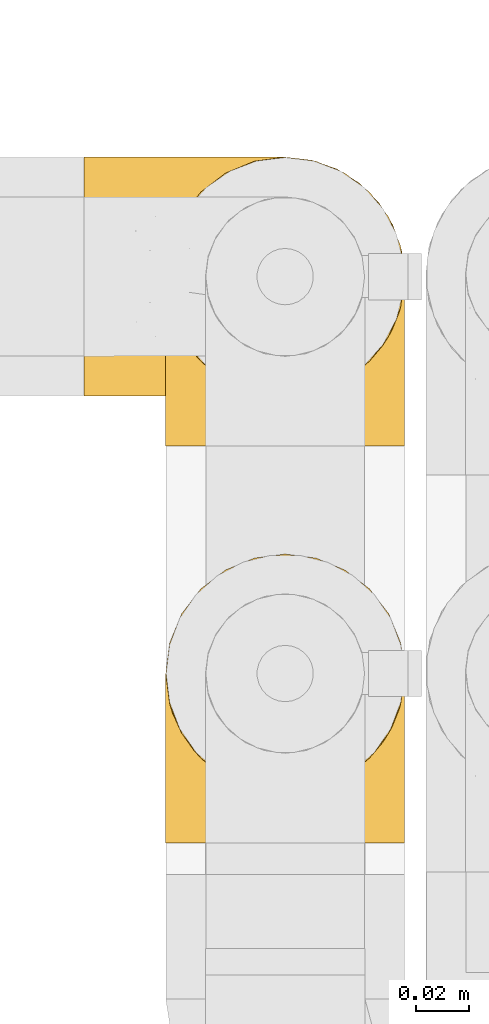
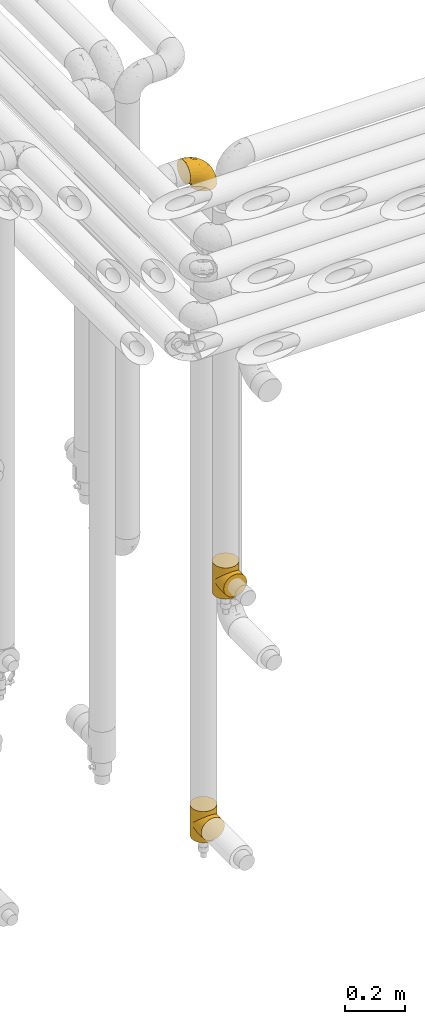
# One storey, part 245 of 827: 3 coverings.
"""IFC2X3 building model written with IfcOpenShell, lengths in millimetres."""

import ifcopenshell
import ifcopenshell.guid

model = None  # the IFC model being written
_history = None  # IfcOwnerHistory: only IFC2X3 demands one
_inside = {}  # id of a spatial element -> (the spatial element, [elements in it])
_under = {}  # id of a project, library or spatial element -> (it, [spatial elements below it])
_declared = {}  # id of a project -> (the project, [libraries it declares])
_typed = {}  # id of a type object -> (the type object, [elements of that type])
_made_of = {}  # id of a material, layer set ... -> (it, [elements and type objects made of it])


def new_model(schema):
    """Start an empty IFC model of exactly this schema.

    Asked for "IFC4X3", IfcOpenShell would pick the latest addendum, in which some entities
    have other attributes; the version numbers below select the first issue.
    IFC2X3 requires an IfcOwnerHistory on every rooted entity: one is made here for all.
    """
    global model, _history
    if schema == "IFC4X3":
        model = ifcopenshell.file(schema_version=(4, 3, 0, 0))
    else:
        model = ifcopenshell.file(schema=schema)
    _inside.clear()
    _under.clear()
    _declared.clear()
    _typed.clear()
    _made_of.clear()
    _history = None
    if model.schema == "IFC2X3":
        org = make("IfcOrganization", Name="unknown")
        user = make(
            "IfcPersonAndOrganization",
            ThePerson=make("IfcPerson", FamilyName="unknown"),
            TheOrganization=org,
        )
        app = make(
            "IfcApplication",
            ApplicationDeveloper=org,
            Version="unknown",
            ApplicationFullName="unknown",
            ApplicationIdentifier="unknown",
        )
        _history = make(
            "IfcOwnerHistory",
            OwningUser=user,
            OwningApplication=app,
            ChangeAction="ADDED",
            CreationDate=0,
        )
    return model


def make(cls, **values):
    """One entity of the class cls with the attributes given. An attribute that is None is left unset."""
    return model.create_entity(
        cls, **{name: value for name, value in values.items() if value is not None}
    )


def entity(cls, *values):
    """Any entity or typed value of the class cls, its attributes in the order of the schema. None: left unset."""
    e = model.create_entity(cls)
    for i, value in enumerate(values):
        if value is not None:
            e[i] = value
    return e


def rooted(cls, **values):
    """An entity with a GlobalId (a new one), such as an element, a storey or a relation."""
    return make(cls, GlobalId=ifcopenshell.guid.new(), OwnerHistory=_history, **values)


def si_unit(unit_type, name, prefix=None):
    """IfcSIUnit, for example si_unit("LENGTHUNIT", "METRE", prefix="MILLI")."""
    return make("IfcSIUnit", UnitType=unit_type, Prefix=prefix, Name=name)


def converted_unit(unit_type, name, factor, base, dimensions=None, offset=None):
    """IfcConversionBasedUnit, such as the inch: factor (a typed value) times the base unit."""
    return make(
        "IfcConversionBasedUnit"
        if offset is None
        else "IfcConversionBasedUnitWithOffset",
        ConversionOffset=offset,
        Dimensions=None
        if dimensions is None
        else entity("IfcDimensionalExponents", *dimensions),
        UnitType=unit_type,
        Name=name,
        ConversionFactor=make(
            "IfcMeasureWithUnit", ValueComponent=factor, UnitComponent=base
        ),
    )


def derived_unit(unit_type, elements):
    """IfcDerivedUnit: a product of units, each with its exponent."""
    return make(
        "IfcDerivedUnit",
        Elements=[
            make("IfcDerivedUnitElement", Unit=unit, Exponent=power)
            for unit, power in elements
        ],
        UnitType=unit_type,
    )


def assignment(units):
    """IfcUnitAssignment: the units of a project."""
    return None if units is None else make("IfcUnitAssignment", Units=units)


def point(xyz):
    """IfcCartesianPoint."""
    return None if xyz is None else make("IfcCartesianPoint", Coordinates=xyz)


def direction(xyz):
    """IfcDirection."""
    return None if xyz is None else make("IfcDirection", DirectionRatios=xyz)


def frame(location, z_axis=None, x_axis=None):
    """IfcAxis2Placement3D, a coordinate frame: its origin and axes. An axis left out is left unset."""
    return make(
        "IfcAxis2Placement3D",
        Location=point(location),
        Axis=direction(z_axis),
        RefDirection=direction(x_axis),
    )


def origin():
    """The frame at (0, 0, 0) with its axes left unset."""
    return frame((0.0, 0.0, 0.0))


def place(relative_to, where):
    """IfcLocalPlacement: puts the frame where relative to a parent placement (None: the world)."""
    return make(
        "IfcLocalPlacement", PlacementRelTo=relative_to, RelativePlacement=where
    )


def context(
    kind, dimensions, precision=None, world=None, true_north=None, identifier=None
):
    """IfcGeometricRepresentationContext, for example the 3D "Model" context."""
    return make(
        "IfcGeometricRepresentationContext",
        ContextIdentifier=identifier,
        ContextType=kind,
        CoordinateSpaceDimension=dimensions,
        Precision=precision,
        WorldCoordinateSystem=world,
        TrueNorth=true_north,
    )


def subcontext(parent, identifier, kind, view, scale=None):
    """IfcGeometricRepresentationSubContext, for example "Body" below "Model"."""
    return make(
        "IfcGeometricRepresentationSubContext",
        ContextIdentifier=identifier,
        ContextType=kind,
        ParentContext=parent,
        TargetScale=scale,
        TargetView=view,
    )


def project(units=None, contexts=None):
    """IfcProject with its units and contexts."""
    return rooted(
        "IfcProject",
        Name="project",
        RepresentationContexts=contexts,
        UnitsInContext=assignment(units),
    )


def spatial(cls, under=None, at=None, **own):
    """A site, building, storey or space (cls), placed at a placement, below another one or the project."""
    s = rooted(cls, ObjectPlacement=at, **own)
    if under is not None:
        _under.setdefault(under.id(), (under, []))[1].append(s)
    return s


def faces_of(points, faces, orient=None, outer=None):
    """IfcFace entities. A face is a list of loops; a loop is a list of indices into points, from 0.

    orient and outer hold one flag for each loop. By default every Orientation is true, the
    first loop of a face is its IfcFaceOuterBound and the others are IfcFaceBound.
    """
    made = []
    for i, loops in enumerate(faces):
        bounds = []
        for j, loop in enumerate(loops):
            is_outer = j == 0 if outer is None else outer[i][j]
            bounds.append(
                make(
                    "IfcFaceOuterBound" if is_outer else "IfcFaceBound",
                    Bound=make("IfcPolyLoop", Polygon=[points[k] for k in loop]),
                    Orientation=True if orient is None else orient[i][j],
                )
            )
        made.append(make("IfcFace", Bounds=bounds))
    return made


def faceted_brep(points, faces, orient=None, outer=None, voids=None):
    """IfcFacetedBrep: a solid bounded by flat faces; with voids (closed shells), ...WithVoids."""
    shared = [point(p) for p in points]
    hull = make("IfcClosedShell", CfsFaces=faces_of(shared, faces, orient, outer))
    if voids is None:
        return make("IfcFacetedBrep", Outer=hull)
    return make(
        "IfcFacetedBrepWithVoids",
        Outer=hull,
        Voids=[
            make(cls, CfsFaces=faces_of(shared, fs, o, b)) for cls, fs, o, b in voids
        ],
    )


def shape(context_of_items, identifier, shape_type, items):
    """IfcShapeRepresentation: the items that make up one representation, for example the "Body"."""
    return make(
        "IfcShapeRepresentation",
        ContextOfItems=context_of_items,
        RepresentationIdentifier=identifier,
        RepresentationType=shape_type,
        Items=items,
    )


def made_of(thing, what):
    """Note that an element or type object is made of a material, layer set ...; save() writes the relation."""
    if what is not None:
        _made_of.setdefault(what.id(), (what, []))[1].append(thing)
    return thing


def element(
    cls,
    number,
    at=None,
    inside=None,
    cuts=None,
    type_object=None,
    material=None,
    context=None,
    identifier="Body",
    shape_type=None,
    held_by="IfcProductDefinitionShape",
    body=None,
    shapes=None,
    **own,
):
    """One element of the class cls, such as IfcWall. Its Tag is "e" and its number.

    at: its placement. inside: the storey or other place that contains it. cuts: it is an
    opening in that element (IfcRelVoidsElement). A single representation is given by context,
    identifier, shape_type and body (its items); several are given by shapes. held_by: the class
    of the entity that holds the representations. save() writes the other relations.
    """
    e = rooted(cls, Tag="e%d" % number, ObjectPlacement=at, **own)
    if body is not None:
        shapes = [shape(context, identifier, shape_type, body)]
    if shapes is not None:
        e.Representation = make(held_by, Representations=shapes)
    if inside is not None:
        _inside.setdefault(inside.id(), (inside, []))[1].append(e)
    if cuts is not None:
        rooted(
            "IfcRelVoidsElement", RelatingBuildingElement=cuts, RelatedOpeningElement=e
        )
    if type_object is not None:
        _typed.setdefault(type_object.id(), (type_object, []))[1].append(e)
    return made_of(e, material)


def aggregate(whole, parts):
    """IfcRelAggregates: a whole, such as a stair, and the parts it consists of."""
    return rooted("IfcRelAggregates", RelatingObject=whole, RelatedObjects=parts)


def save(model, path):
    """Write the relations noted so far, then the file.

    IfcRelAggregates (storeys below a building ...), IfcRelContainedInSpatialStructure (elements
    in a storey), IfcRelDefinesByType, IfcRelAssociatesMaterial and IfcRelDeclares: one each for
    every whole, place, type object, material and project.
    """
    for whole, parts in _under.values():
        aggregate(whole, parts)
    for where, things in _inside.values():
        rooted(
            "IfcRelContainedInSpatialStructure",
            RelatedElements=things,
            RelatingStructure=where,
        )
    for kind, things in _typed.values():
        rooted("IfcRelDefinesByType", RelatedObjects=things, RelatingType=kind)
    for what, things in _made_of.values():
        rooted("IfcRelAssociatesMaterial", RelatedObjects=things, RelatingMaterial=what)
    for by, libraries in _declared.values():
        rooted("IfcRelDeclares", RelatingContext=by, RelatedDefinitions=libraries)
    model.write(path)


model = new_model("IFC2X3")

# Units and contexts
model_context = context("Model", 3, precision=0.01, world=origin(), true_north=direction((6.12303176911189e-17, 1.0)))
body_context = subcontext(model_context, "Body", "Model", "MODEL_VIEW")
ifc_project = project(units=[si_unit("LENGTHUNIT", "METRE", prefix="MILLI"), si_unit("AREAUNIT", "SQUARE_METRE"), si_unit("VOLUMEUNIT", "CUBIC_METRE"), converted_unit("PLANEANGLEUNIT", "DEGREE", entity("IfcRatioMeasure", 0.0174532925199433), si_unit("PLANEANGLEUNIT", "RADIAN"), dimensions=[0, 0, 0, 0, 0, 0, 0]), si_unit("MASSUNIT", "GRAM", prefix="KILO"), derived_unit("MASSDENSITYUNIT", [(si_unit("MASSUNIT", "GRAM", prefix="KILO"), 1), (si_unit("LENGTHUNIT", "METRE"), -3)]), derived_unit("MOMENTOFINERTIAUNIT", [(si_unit("LENGTHUNIT", "METRE"), 4)]), si_unit("TIMEUNIT", "SECOND"), si_unit("FREQUENCYUNIT", "HERTZ"), si_unit("THERMODYNAMICTEMPERATUREUNIT", "DEGREE_CELSIUS"), derived_unit("THERMALTRANSMITTANCEUNIT", [(si_unit("MASSUNIT", "GRAM", prefix="KILO"), 1), (si_unit("THERMODYNAMICTEMPERATUREUNIT", "KELVIN"), -1), (si_unit("TIMEUNIT", "SECOND"), -3)]), derived_unit("VOLUMETRICFLOWRATEUNIT", [(si_unit("LENGTHUNIT", "METRE"), 3), (si_unit("TIMEUNIT", "SECOND"), -1)]), derived_unit("MASSFLOWRATEUNIT", [(si_unit("MASSUNIT", "GRAM", prefix="KILO"), 1), (si_unit("TIMEUNIT", "SECOND"), -1)]), derived_unit("ROTATIONALFREQUENCYUNIT", [(si_unit("TIMEUNIT", "SECOND"), -1)]), si_unit("ELECTRICCURRENTUNIT", "AMPERE"), si_unit("ELECTRICVOLTAGEUNIT", "VOLT"), si_unit("POWERUNIT", "WATT"), si_unit("FORCEUNIT", "NEWTON", prefix="KILO"), si_unit("ILLUMINANCEUNIT", "LUX"), si_unit("LUMINOUSFLUXUNIT", "LUMEN"), si_unit("LUMINOUSINTENSITYUNIT", "CANDELA"), derived_unit("USERDEFINED", [(si_unit("MASSUNIT", "GRAM", prefix="KILO"), -1), (si_unit("LENGTHUNIT", "METRE"), -2), (si_unit("TIMEUNIT", "SECOND"), 3), (si_unit("LUMINOUSFLUXUNIT", "LUMEN"), 1)]), derived_unit("LINEARVELOCITYUNIT", [(si_unit("LENGTHUNIT", "METRE"), 1), (si_unit("TIMEUNIT", "SECOND"), -1)]), si_unit("PRESSUREUNIT", "PASCAL"), derived_unit("USERDEFINED", [(si_unit("LENGTHUNIT", "METRE"), -2), (si_unit("MASSUNIT", "GRAM", prefix="KILO"), 1), (si_unit("TIMEUNIT", "SECOND"), -2)]), derived_unit("LINEARFORCEUNIT", [(si_unit("MASSUNIT", "GRAM", prefix="KILO"), 1), (si_unit("LENGTHUNIT", "METRE"), 1), (si_unit("TIMEUNIT", "SECOND"), -2), (si_unit("LENGTHUNIT", "METRE"), -1)]), derived_unit("PLANARFORCEUNIT", [(si_unit("MASSUNIT", "GRAM", prefix="KILO"), 1), (si_unit("LENGTHUNIT", "METRE"), 1), (si_unit("TIMEUNIT", "SECOND"), -2), (si_unit("LENGTHUNIT", "METRE"), -2)])], contexts=[model_context])

# Site, building, storey
site_placement = place(None, origin())
site = spatial("IfcSite", under=ifc_project, at=site_placement, CompositionType="ELEMENT")
building_placement = place(site_placement, origin())
building = spatial("IfcBuilding", under=site, at=building_placement, CompositionType="ELEMENT")
storey_placement = place(building_placement, frame((0.0, 0.0, 28200.0)))
storey = spatial("IfcBuildingStorey", under=building, at=storey_placement, Name="08", CompositionType="ELEMENT", Elevation=28200.0)

# Coverings
covering_1_placement = place(storey_placement, frame((31569.16, 15092.26, 2922.4)))
element("IfcCovering", 1, at=covering_1_placement, inside=storey, Name=":ADSK_", ObjectType=":ADSK_", PredefinedType="INSULATION", context=body_context, shape_type="Brep", body=[
    faceted_brep([(87.65, 90.76, 1.6), (97.19, 87.42, 1.6), (105.75, 82.04, 1.6), (112.9, 74.89, 1.6), (118.28, 66.33, 1.6), (121.61, 56.79, 1.6), (122.75, 46.75, 1.6), (121.61, 36.69, 1.6), (118.27, 27.15, 1.6), (112.89, 18.59, 1.6), (105.74, 11.44, 1.6), (97.18, 6.06, 1.6), (87.64, 2.73, 1.6), (77.6, 1.6, 1.6), (67.54, 2.73, 1.6), (58.0, 6.07, 1.6), (49.44, 11.45, 1.6), (42.29, 18.6, 1.6), (36.91, 27.16, 1.6), (33.58, 36.7, 1.6), (32.45, 46.75, 1.6), (33.58, 56.8, 1.6), (36.92, 66.34, 1.6), (42.3, 74.9, 1.6), (49.45, 82.05, 1.6), (58.01, 87.43, 1.6), (67.55, 90.76, 1.6), (77.6, 91.9, 1.6), (1.6, 35.06, 33.98), (1.6, 24.17, 38.49), (1.6, 14.82, 45.67), (1.6, 7.64, 55.02), (1.6, 3.13, 65.91), (1.6, 1.6, 77.6), (1.6, 3.13, 89.28), (1.6, 7.64, 100.17), (1.6, 14.82, 109.52), (1.6, 24.17, 116.7), (1.6, 35.06, 121.21), (1.6, 46.75, 122.75), (1.6, 58.43, 121.21), (1.6, 69.32, 116.7), (1.6, 78.67, 109.52), (1.6, 85.85, 100.17), (1.6, 90.36, 89.28), (1.6, 91.9, 77.6), (1.6, 90.36, 65.91), (1.6, 85.85, 55.02), (1.6, 78.67, 45.67), (1.6, 69.32, 38.49), (1.6, 58.43, 33.98), (1.6, 46.75, 32.45), (99.61, 46.75, 72.81), (95.26, 55.2, 77.17), (86.21, 46.75, 86.21), (39.03, 46.75, 116.82), (30.75, 54.53, 118.49), (23.8, 46.75, 119.23), (60.8, 59.63, 105.14), (85.37, 62.07, 85.37), (73.64, 71.86, 89.33), (31.01, 62.65, 116.14), (49.14, 71.33, 105.06), (23.88, 72.93, 112.15), (82.74, 91.2, 22.95), (43.48, 86.31, 89.91), (29.47, 80.89, 103.39), (56.38, 79.49, 93.6), (72.18, 90.68, 51.41), (72.24, 86.84, 67.71), (87.6, 87.38, 43.53), (107.24, 76.87, 30.91), (101.1, 83.73, 23.58), (95.16, 81.03, 50.07), (71.81, 91.9, 30.68), (63.57, 91.9, 43.01), (55.34, 91.9, 55.34), (23.66, 91.03, 83.48), (20.55, 87.58, 94.96), (107.97, 56.52, 57.29), (116.82, 46.75, 39.03), (117.03, 60.4, 30.66), (30.68, 91.9, 71.81), (21.51, 91.9, 73.63), (12.33, 91.9, 75.46), (106.17, 67.87, 51.57), (52.37, 90.35, 73.13), (114.51, 69.57, 23.16), (119.23, 46.75, 23.8), (78.37, 79.91, 75.6), (75.46, 91.9, 12.33), (73.63, 91.9, 21.51), (101.51, 74.99, 50.46), (72.81, 46.75, 99.61), (43.01, 91.9, 63.57), (92.6, 88.53, 21.26), (91.86, 72.65, 69.54), (55.92, 46.75, 108.21), (99.01, 62.97, 68.42), (108.21, 46.75, 55.92), (32.05, 66.2, 19.36), (30.22, 56.6, 15.76), (23.37, 59.89, 26.13), (28.43, 90.95, 62.78), (16.44, 90.22, 63.65), (37.1, 76.64, 24.34), (28.88, 71.58, 28.46), (33.93, 79.99, 33.53), (50.17, 89.54, 39.46), (40.57, 89.97, 51.05), (47.62, 81.32, 10.94), (39.9, 74.56, 14.55), (47.92, 84.15, 22.21), (34.27, 90.37, 57.05), (24.65, 87.82, 54.0), (62.6, 90.98, 29.19), (66.18, 90.96, 18.85), (11.74, 85.14, 52.84), (13.89, 58.11, 31.47), (17.02, 46.75, 28.31), (15.86, 78.39, 43.0), (57.71, 88.22, 16.9), (9.11, 66.06, 35.98), (18.55, 68.6, 33.91), (34.74, 63.78, 9.97), (54.95, 88.42, 25.93), (57.35, 90.61, 35.61), (22.03, 83.8, 47.45), (24.8, 77.98, 38.26), (69.07, 91.22, 11.7), (42.31, 83.46, 30.13), (29.63, 46.75, 12.12), (28.31, 46.75, 17.02), (30.23, 84.66, 44.39), (40.13, 86.33, 39.83), (22.67, 46.75, 22.67), (12.12, 46.75, 29.63), (15.86, 15.1, 43.0), (22.03, 9.69, 47.45), (24.8, 15.52, 38.26), (30.23, 8.83, 44.38), (13.88, 35.39, 31.47), (47.61, 12.18, 10.93), (73.63, 1.6, 21.51), (66.17, 2.53, 18.84), (69.07, 2.27, 11.7), (30.22, 36.9, 15.76), (32.04, 27.31, 19.36), (23.36, 33.62, 26.14), (54.93, 5.07, 25.94), (47.91, 9.36, 22.21), (57.69, 5.27, 16.9), (9.1, 27.43, 35.98), (21.51, 1.6, 73.63), (12.33, 1.6, 75.46), (42.29, 10.05, 30.12), (37.09, 16.87, 24.33), (11.74, 8.35, 52.84), (16.44, 3.27, 63.65), (30.68, 1.6, 71.81), (28.86, 21.94, 28.45), (34.74, 29.72, 9.97), (63.57, 1.6, 43.01), (55.34, 1.6, 55.34), (50.17, 3.96, 39.46), (75.46, 1.6, 12.33), (39.89, 18.95, 14.54), (28.43, 2.54, 62.78), (34.27, 3.12, 57.05), (43.01, 1.6, 63.57), (62.59, 2.51, 29.2), (40.57, 3.52, 51.05), (40.13, 7.17, 39.81), (71.81, 1.6, 30.68), (33.92, 13.52, 33.52), (57.34, 2.88, 35.61), (24.65, 5.67, 54.0), (18.54, 24.89, 33.91), (29.47, 12.6, 103.39), (43.48, 7.18, 89.91), (56.4, 14.0, 93.6), (49.17, 22.16, 105.05), (73.69, 21.61, 89.27), (52.37, 3.14, 73.13), (72.26, 6.65, 67.67), (91.88, 20.82, 69.49), (85.36, 31.41, 85.36), (20.55, 5.91, 94.96), (23.66, 2.46, 83.48), (60.8, 33.87, 105.14), (31.02, 30.84, 116.13), (30.75, 38.96, 118.49), (23.9, 20.56, 112.15), (72.17, 2.81, 51.41), (87.59, 6.1, 43.51), (82.74, 2.29, 22.95), (117.03, 33.08, 30.66), (107.23, 16.61, 30.91), (107.97, 36.96, 57.3), (101.08, 9.75, 23.58), (106.17, 25.61, 51.56), (99.01, 30.5, 68.41), (114.5, 23.91, 23.16), (95.15, 12.45, 50.07), (101.5, 18.49, 50.45), (92.59, 4.96, 21.25), (78.38, 13.56, 75.56), (95.27, 38.28, 77.16)], [[[0, 1, 2, 3, 4, 5, 6, 7, 8, 9, 10, 11, 12, 13, 14, 15, 16, 17, 18, 19, 20, 21, 22, 23, 24, 25, 26, 27]], [[28, 29, 30, 31, 32, 33, 34, 35, 36, 37, 38, 39, 40, 41, 42, 43, 44, 45, 46, 47, 48, 49, 50, 51]], [[52, 53, 54]], [[55, 56, 57]], [[58, 59, 60]], [[61, 62, 63]], [[27, 64, 0]], [[65, 66, 67]], [[41, 40, 61]], [[68, 69, 70]], [[66, 43, 42]], [[63, 42, 41]], [[71, 72, 73]], [[72, 2, 1]], [[68, 74, 75, 76]], [[45, 44, 77]], [[43, 78, 44]], [[79, 80, 81]], [[77, 82, 83, 84, 45]], [[79, 81, 85]], [[71, 2, 72]], [[65, 86, 77]], [[4, 81, 5]], [[66, 65, 78]], [[4, 3, 87]], [[81, 88, 5]], [[63, 66, 42]], [[68, 70, 64]], [[67, 60, 89]], [[71, 3, 2]], [[64, 27, 90, 91, 74]], [[92, 71, 73]], [[40, 57, 56]], [[59, 93, 54]], [[86, 76, 94, 82]], [[1, 0, 95]], [[58, 62, 61]], [[60, 96, 89]], [[85, 81, 87]], [[56, 97, 58]], [[65, 67, 69]], [[87, 81, 4]], [[67, 89, 69]], [[61, 63, 41]], [[95, 72, 1]], [[73, 72, 70]], [[69, 73, 70]], [[73, 89, 96]], [[3, 71, 87]], [[85, 87, 71]], [[58, 61, 56]], [[59, 58, 93]], [[76, 86, 68]], [[69, 89, 73]], [[68, 86, 69]], [[65, 69, 86]], [[68, 64, 74]], [[95, 64, 70]], [[98, 79, 85]], [[79, 52, 99, 80]], [[66, 62, 67]], [[62, 58, 60]], [[62, 60, 67]], [[59, 98, 96]], [[59, 96, 60]], [[96, 85, 92]], [[88, 81, 80]], [[88, 6, 5]], [[66, 63, 62]], [[64, 95, 0]], [[72, 95, 70]], [[77, 44, 78]], [[86, 82, 77]], [[40, 39, 57]], [[96, 98, 85]], [[40, 56, 61]], [[66, 78, 43]], [[77, 78, 65]], [[79, 98, 53]], [[96, 92, 73]], [[85, 71, 92]], [[97, 56, 55]], [[97, 93, 58]], [[53, 98, 59]], [[54, 53, 59]], [[79, 53, 52]], [[100, 101, 102]], [[46, 45, 84, 83]], [[103, 104, 82]], [[82, 104, 83]], [[105, 106, 107]], [[108, 109, 76]], [[110, 111, 112]], [[103, 113, 114]], [[115, 74, 116]], [[48, 47, 117]], [[118, 102, 119]], [[49, 48, 120]], [[74, 91, 116]], [[116, 121, 115]], [[49, 122, 50]], [[123, 106, 102]], [[124, 111, 22]], [[125, 126, 115]], [[23, 22, 111]], [[24, 110, 121]], [[120, 127, 128]], [[90, 26, 129]], [[27, 26, 90]], [[121, 125, 115]], [[24, 121, 25]], [[130, 105, 107]], [[129, 25, 116]], [[21, 20, 131]], [[120, 123, 122]], [[112, 105, 130]], [[50, 118, 51]], [[21, 124, 22]], [[101, 131, 132]], [[117, 120, 48]], [[24, 23, 110]], [[127, 114, 133]], [[75, 108, 76]], [[107, 134, 130]], [[133, 114, 113]], [[129, 116, 91]], [[25, 121, 116]], [[121, 112, 125]], [[75, 74, 115]], [[101, 135, 102]], [[131, 101, 21]], [[101, 100, 124]], [[128, 127, 133]], [[119, 136, 51, 118]], [[104, 47, 46]], [[83, 104, 46]], [[117, 104, 114]], [[101, 124, 21]], [[111, 124, 100]], [[102, 118, 123]], [[133, 134, 107]], [[111, 110, 23]], [[114, 104, 103]], [[94, 76, 109]], [[121, 110, 112]], [[122, 118, 50]], [[134, 109, 108]], [[133, 107, 128]], [[112, 108, 125]], [[126, 125, 108]], [[108, 75, 126]], [[75, 115, 126]], [[109, 134, 133]], [[130, 108, 112]], [[108, 130, 134]], [[105, 112, 111]], [[111, 100, 105]], [[106, 105, 100]], [[102, 106, 100]], [[128, 106, 123]], [[90, 129, 91]], [[25, 129, 26]], [[104, 117, 47]], [[117, 114, 127]], [[82, 94, 103]], [[113, 94, 109]], [[94, 113, 103]], [[133, 113, 109]], [[106, 128, 107]], [[123, 120, 128]], [[120, 122, 49]], [[118, 122, 123]], [[135, 101, 132]], [[135, 119, 102]], [[117, 127, 120]], [[30, 29, 137]], [[138, 139, 140]], [[51, 136, 119, 141]], [[142, 17, 16]], [[143, 144, 145]], [[146, 147, 148]], [[149, 150, 151]], [[152, 29, 28]], [[33, 32, 153, 154]], [[150, 155, 156]], [[157, 31, 30]], [[153, 158, 159]], [[29, 152, 137]], [[148, 141, 119]], [[156, 160, 147]], [[148, 135, 146]], [[137, 138, 157]], [[19, 161, 146]], [[162, 163, 164]], [[14, 13, 165]], [[153, 32, 158]], [[147, 161, 166]], [[18, 17, 166]], [[167, 168, 169]], [[166, 150, 156]], [[151, 150, 142]], [[151, 170, 149]], [[151, 16, 15]], [[171, 140, 172]], [[165, 143, 145]], [[173, 170, 144]], [[142, 166, 17]], [[19, 131, 20]], [[144, 170, 151]], [[18, 161, 19]], [[173, 144, 143]], [[140, 139, 174]], [[171, 164, 163]], [[164, 172, 155]], [[151, 15, 144]], [[145, 15, 14]], [[173, 162, 170]], [[149, 175, 164]], [[19, 146, 131]], [[132, 131, 146]], [[160, 148, 147]], [[159, 158, 167]], [[135, 132, 146]], [[158, 32, 31]], [[157, 158, 31]], [[167, 158, 176]], [[166, 161, 18]], [[146, 161, 147]], [[148, 177, 141]], [[171, 168, 140]], [[171, 163, 169]], [[151, 142, 16]], [[166, 142, 150]], [[152, 141, 177]], [[51, 141, 28]], [[138, 140, 176]], [[172, 140, 174]], [[175, 149, 170]], [[164, 150, 149]], [[170, 162, 175]], [[162, 164, 175]], [[155, 172, 174]], [[171, 172, 164]], [[155, 174, 156]], [[164, 155, 150]], [[160, 156, 174]], [[147, 166, 156]], [[139, 160, 174]], [[148, 160, 177]], [[15, 145, 144]], [[165, 145, 14]], [[137, 157, 30]], [[158, 157, 176]], [[168, 167, 176]], [[169, 159, 167]], [[140, 168, 176]], [[169, 168, 171]], [[137, 177, 139]], [[160, 139, 177]], [[141, 152, 28]], [[137, 152, 177]], [[148, 119, 135]], [[157, 138, 176]], [[139, 138, 137]], [[178, 179, 180]], [[181, 180, 182]], [[179, 183, 184]], [[185, 186, 182]], [[187, 188, 179]], [[188, 33, 154, 153, 159]], [[181, 189, 190]], [[35, 34, 187]], [[191, 38, 190]], [[192, 178, 181]], [[179, 184, 180]], [[192, 190, 37]], [[37, 190, 38]], [[36, 35, 178]], [[54, 93, 186]], [[35, 187, 178]], [[193, 194, 184]], [[195, 173, 143, 165, 13]], [[195, 193, 173]], [[193, 163, 162, 173]], [[13, 12, 195]], [[8, 7, 196]], [[9, 197, 10]], [[198, 80, 99, 52]], [[196, 7, 88]], [[197, 199, 10]], [[182, 189, 181]], [[200, 198, 201]], [[200, 196, 198]], [[9, 8, 202]], [[194, 199, 203]], [[192, 37, 36]], [[80, 196, 88]], [[183, 159, 169, 163]], [[188, 34, 33]], [[202, 200, 197]], [[185, 203, 204]], [[202, 8, 196]], [[10, 199, 11]], [[12, 11, 205]], [[38, 191, 57]], [[189, 97, 191]], [[203, 199, 197]], [[205, 199, 194]], [[204, 203, 197]], [[184, 203, 206]], [[200, 202, 196]], [[197, 9, 202]], [[207, 54, 186]], [[97, 55, 191]], [[194, 203, 184]], [[183, 163, 193]], [[184, 206, 180]], [[183, 193, 184]], [[205, 195, 12]], [[193, 195, 194]], [[80, 198, 196]], [[207, 186, 201]], [[182, 180, 206]], [[181, 178, 180]], [[185, 182, 206]], [[182, 186, 189]], [[203, 185, 206]], [[185, 200, 201]], [[7, 6, 88]], [[178, 192, 36]], [[190, 192, 181]], [[199, 205, 11]], [[195, 205, 194]], [[159, 183, 188]], [[179, 188, 183]], [[57, 191, 55]], [[57, 39, 38]], [[189, 191, 190]], [[188, 187, 34]], [[178, 187, 179]], [[186, 93, 189]], [[197, 200, 204]], [[185, 204, 200]], [[189, 93, 97]], [[207, 198, 52]], [[185, 201, 186]], [[198, 207, 201]], [[54, 207, 52]]]),
])
covering_2_placement = place(storey_placement, frame((31600.01, 15075.0, 251.5)))
element("IfcCovering", 2, at=covering_2_placement, inside=storey, Name=":ADSK_", ObjectType=":ADSK_", PredefinedType="INSULATION", context=body_context, shape_type="Brep", body=[
    faceted_brep([(91.39, 57.25, 70.75), (91.9, 64.0, 128.0), (90.36, 52.31, 128.0), (85.85, 41.43, 128.0), (87.26, 44.06, 83.94), (83.54, 37.83, 90.17), (78.67, 32.07, 128.0), (91.9, 64.0, 64.0), (91.39, 57.25, 57.25), (91.9, 64.0, 0.0), (89.85, 50.57, 77.43), (72.42, 26.86, 101.14), (69.32, 24.9, 128.0), (64.9, 22.66, 105.34), (63.88, 22.64, 128.0), (58.43, 20.39, 128.0), (56.19, 19.85, 108.15), (46.75, 18.85, 128.0), (78.62, 32.02, 95.98), (46.75, 18.85, 109.15), (46.75, 18.85, 0.0), (56.19, 19.85, 19.85), (46.75, 18.85, 18.85), (36.15, 20.11, 107.89), (35.06, 20.39, 128.0), (26.59, 23.6, 104.4), (24.17, 24.9, 128.0), (18.6, 28.7, 99.3), (14.82, 32.07, 128.0), (36.15, 20.11, 20.11), (12.26, 34.86, 93.14), (7.5, 41.68, 86.32), (7.64, 41.42, 128.0), (4.19, 48.92, 79.08), (3.13, 52.31, 128.0), (2.24, 56.41, 71.59), (1.6, 64.0, 128.0), (1.6, 64.0, 64.0), (2.24, 56.41, 56.41), (1.6, 64.0, 0.0), (24.17, 103.1, 0.0), (35.06, 107.61, 0.0), (46.75, 109.15, 0.0), (58.43, 107.61, 0.0), (69.32, 103.1, 0.0), (78.67, 95.93, 0.0), (85.85, 86.58, 0.0), (90.36, 75.69, 0.0), (90.36, 52.31, 0.0), (85.85, 41.43, 0.0), (78.67, 32.07, 0.0), (69.32, 24.9, 0.0), (63.88, 22.64, 0.0), (58.43, 20.39, 0.0), (35.06, 20.39, 0.0), (24.17, 24.9, 0.0), (14.82, 32.07, 0.0), (7.64, 41.43, 0.0), (3.13, 52.31, 0.0), (3.13, 75.69, 0.0), (7.64, 86.58, 0.0), (14.82, 95.93, 0.0), (78.67, 95.93, 128.0), (69.32, 103.1, 128.0), (58.43, 107.61, 128.0), (46.75, 109.15, 128.0), (35.06, 107.61, 128.0), (24.17, 103.1, 128.0), (14.82, 95.93, 128.0), (7.64, 86.58, 128.0), (3.13, 75.69, 128.0), (90.36, 75.69, 128.0), (85.85, 86.58, 128.0), (89.85, 50.57, 50.57), (87.26, 44.06, 44.06), (83.54, 37.83, 37.83), (78.62, 32.02, 32.02), (72.42, 26.86, 26.86), (64.9, 22.66, 22.66), (26.59, 23.6, 23.6), (18.6, 28.7, 28.7), (12.26, 34.86, 34.86), (7.5, 41.68, 41.68), (4.19, 48.92, 48.92), (78.67, 0.0, 95.93), (69.32, 0.0, 103.1), (63.88, 0.0, 105.36), (58.43, 0.0, 107.61), (46.75, 0.0, 109.15), (35.06, 0.0, 107.61), (24.17, 0.0, 103.1), (14.82, 0.0, 95.93), (7.64, 0.0, 86.57), (3.13, 0.0, 75.69), (1.6, 0.0, 64.0), (3.13, 0.0, 52.31), (7.64, 0.0, 41.42), (14.82, 0.0, 32.07), (24.17, 0.0, 24.9), (35.06, 0.0, 20.39), (46.75, 0.0, 18.85), (58.43, 0.0, 20.39), (63.88, 0.0, 22.64), (69.32, 0.0, 24.9), (78.67, 0.0, 32.07), (85.85, 0.0, 41.42), (90.36, 0.0, 52.31), (91.9, 0.0, 64.0), (90.36, 0.0, 75.69), (85.85, 0.0, 86.57)], [[[0, 1, 2]], [[2, 3, 4]], [[5, 3, 6]], [[5, 4, 3]], [[0, 7, 1]], [[7, 8, 9]], [[4, 10, 2]], [[0, 2, 10]], [[11, 6, 12]], [[13, 12, 14, 15]], [[16, 15, 17]], [[11, 18, 6]], [[16, 13, 15]], [[19, 16, 17]], [[20, 21, 22]], [[11, 12, 13]], [[6, 18, 5]], [[23, 17, 24]], [[25, 24, 26]], [[27, 26, 28]], [[23, 19, 17]], [[22, 29, 20]], [[27, 25, 26]], [[23, 24, 25]], [[28, 30, 27]], [[31, 30, 32]], [[32, 30, 28]], [[33, 32, 34]], [[35, 34, 36]], [[33, 31, 32]], [[37, 35, 36]], [[38, 37, 39]], [[33, 34, 35]], [[40, 41, 42, 43, 44, 45, 46, 47, 9, 48, 49, 50, 51, 52, 53, 20, 54, 55, 56, 57, 58, 39, 59, 60, 61]], [[62, 63, 64, 65, 66, 67, 68, 69, 70, 36, 34, 32, 28, 26, 24, 17, 15, 14, 12, 6, 3, 2, 1, 71, 72]], [[63, 62, 45, 44]], [[42, 65, 64, 43]], [[44, 43, 64, 63]], [[46, 72, 71, 47]], [[1, 7, 9, 47, 71]], [[45, 62, 72, 46]], [[73, 74, 48]], [[8, 73, 48]], [[9, 8, 48]], [[49, 75, 50]], [[49, 48, 74]], [[75, 49, 74]], [[76, 77, 50]], [[78, 21, 53]], [[78, 53, 52, 51]], [[77, 78, 51]], [[50, 77, 51]], [[21, 20, 53]], [[76, 50, 75]], [[79, 80, 55]], [[29, 79, 54]], [[20, 29, 54]], [[54, 79, 55]], [[80, 56, 55]], [[80, 81, 56]], [[82, 83, 57]], [[83, 38, 58]], [[81, 57, 56]], [[81, 82, 57]], [[57, 83, 58]], [[38, 39, 58]], [[37, 36, 70, 59, 39]], [[59, 70, 69, 60]], [[69, 68, 61, 60]], [[61, 68, 67, 40]], [[40, 67, 66, 41]], [[41, 66, 65, 42]], [[84, 85, 86, 87, 88, 89, 90, 91, 92, 93, 94, 95, 96, 97, 98, 99, 100, 101, 102, 103, 104, 105, 106, 107, 108, 109]], [[16, 19, 88]], [[16, 88, 87]], [[13, 87, 86, 85]], [[13, 16, 87]], [[84, 18, 11]], [[13, 85, 11]], [[11, 85, 84]], [[5, 84, 109]], [[4, 109, 108]], [[0, 108, 107]], [[4, 5, 109]], [[0, 10, 108]], [[7, 0, 107]], [[4, 108, 10]], [[84, 5, 18]], [[8, 107, 106]], [[106, 105, 74]], [[75, 105, 104]], [[75, 74, 105]], [[8, 7, 107]], [[74, 73, 106]], [[8, 106, 73]], [[77, 104, 103]], [[78, 103, 102, 101]], [[21, 101, 100]], [[77, 76, 104]], [[21, 78, 101]], [[22, 21, 100]], [[77, 103, 78]], [[104, 76, 75]], [[29, 100, 99]], [[79, 99, 98]], [[80, 98, 97]], [[29, 22, 100]], [[80, 79, 98]], [[29, 99, 79]], [[97, 81, 80]], [[82, 81, 96]], [[96, 81, 97]], [[83, 96, 95]], [[38, 95, 94]], [[83, 82, 96]], [[37, 38, 94]], [[83, 95, 38]], [[35, 94, 93]], [[93, 92, 33]], [[30, 92, 91]], [[30, 31, 92]], [[35, 37, 94]], [[31, 33, 92]], [[35, 93, 33]], [[27, 91, 90]], [[25, 90, 89]], [[23, 89, 88]], [[25, 27, 90]], [[19, 23, 88]], [[25, 89, 23]], [[91, 27, 30]]]),
])
covering_3_placement = place(storey_placement, frame((31600.01, 14925.0, 1341.5)))
element("IfcCovering", 3, at=covering_3_placement, inside=storey, Name=":ADSK_", ObjectType=":ADSK_", PredefinedType="INSULATION", context=body_context, shape_type="Brep", body=[
    faceted_brep([(91.39, 57.25, 70.75), (91.9, 64.0, 128.0), (90.36, 52.31, 128.0), (85.85, 41.43, 128.0), (87.26, 44.06, 83.94), (83.54, 37.83, 90.17), (78.67, 32.07, 128.0), (91.9, 64.0, 64.0), (91.39, 57.25, 57.25), (91.9, 64.0, 0.0), (89.85, 50.57, 77.43), (72.42, 26.86, 101.14), (69.32, 24.9, 128.0), (64.9, 22.66, 105.34), (63.88, 22.64, 128.0), (58.43, 20.39, 128.0), (56.19, 19.85, 108.15), (46.75, 18.85, 128.0), (78.62, 32.02, 95.98), (46.75, 18.85, 109.15), (46.75, 18.85, 0.0), (56.19, 19.85, 19.85), (46.75, 18.85, 18.85), (36.15, 20.11, 107.89), (35.06, 20.39, 128.0), (26.59, 23.6, 104.4), (24.17, 24.9, 128.0), (18.6, 28.7, 99.3), (14.82, 32.07, 128.0), (36.15, 20.11, 20.11), (12.26, 34.86, 93.14), (7.5, 41.68, 86.32), (7.64, 41.42, 128.0), (4.19, 48.92, 79.08), (3.13, 52.31, 128.0), (2.24, 56.41, 71.59), (1.6, 64.0, 128.0), (1.6, 64.0, 64.0), (2.24, 56.41, 56.41), (1.6, 64.0, 0.0), (24.17, 103.1, 0.0), (35.06, 107.61, 0.0), (46.75, 109.15, 0.0), (58.43, 107.61, 0.0), (69.32, 103.1, 0.0), (78.67, 95.93, 0.0), (85.85, 86.58, 0.0), (90.36, 75.69, 0.0), (90.36, 52.31, 0.0), (85.85, 41.43, 0.0), (78.67, 32.07, 0.0), (69.32, 24.9, 0.0), (63.88, 22.64, 0.0), (58.43, 20.39, 0.0), (35.06, 20.39, 0.0), (24.17, 24.9, 0.0), (14.82, 32.07, 0.0), (7.64, 41.43, 0.0), (3.13, 52.31, 0.0), (3.13, 75.69, 0.0), (7.64, 86.58, 0.0), (14.82, 95.93, 0.0), (78.67, 95.93, 128.0), (69.32, 103.1, 128.0), (58.43, 107.61, 128.0), (46.75, 109.15, 128.0), (35.06, 107.61, 128.0), (24.17, 103.1, 128.0), (14.82, 95.93, 128.0), (7.64, 86.58, 128.0), (3.13, 75.69, 128.0), (90.36, 75.69, 128.0), (85.85, 86.58, 128.0), (89.85, 50.57, 50.57), (87.26, 44.06, 44.06), (83.54, 37.83, 37.83), (78.62, 32.02, 32.02), (72.42, 26.86, 26.86), (64.9, 22.66, 22.66), (26.59, 23.6, 23.6), (18.6, 28.7, 28.7), (12.26, 34.86, 34.86), (7.5, 41.68, 41.68), (4.19, 48.92, 48.92), (78.67, 0.0, 95.93), (69.32, 0.0, 103.1), (63.88, 0.0, 105.36), (58.43, 0.0, 107.61), (46.75, 0.0, 109.15), (35.06, 0.0, 107.61), (24.17, 0.0, 103.1), (14.82, 0.0, 95.93), (7.64, 0.0, 86.57), (3.13, 0.0, 75.69), (1.6, 0.0, 64.0), (3.13, 0.0, 52.31), (7.64, 0.0, 41.42), (14.82, 0.0, 32.07), (24.17, 0.0, 24.9), (35.06, 0.0, 20.39), (46.75, 0.0, 18.85), (58.43, 0.0, 20.39), (63.88, 0.0, 22.64), (69.32, 0.0, 24.9), (78.67, 0.0, 32.07), (85.85, 0.0, 41.42), (90.36, 0.0, 52.31), (91.9, 0.0, 64.0), (90.36, 0.0, 75.69), (85.85, 0.0, 86.57)], [[[0, 1, 2]], [[2, 3, 4]], [[5, 3, 6]], [[5, 4, 3]], [[0, 7, 1]], [[7, 8, 9]], [[4, 10, 2]], [[0, 2, 10]], [[11, 6, 12]], [[13, 12, 14, 15]], [[16, 15, 17]], [[11, 18, 6]], [[16, 13, 15]], [[19, 16, 17]], [[20, 21, 22]], [[11, 12, 13]], [[6, 18, 5]], [[23, 17, 24]], [[25, 24, 26]], [[27, 26, 28]], [[23, 19, 17]], [[22, 29, 20]], [[27, 25, 26]], [[23, 24, 25]], [[28, 30, 27]], [[31, 30, 32]], [[32, 30, 28]], [[33, 32, 34]], [[35, 34, 36]], [[33, 31, 32]], [[37, 35, 36]], [[38, 37, 39]], [[33, 34, 35]], [[40, 41, 42, 43, 44, 45, 46, 47, 9, 48, 49, 50, 51, 52, 53, 20, 54, 55, 56, 57, 58, 39, 59, 60, 61]], [[62, 63, 64, 65, 66, 67, 68, 69, 70, 36, 34, 32, 28, 26, 24, 17, 15, 14, 12, 6, 3, 2, 1, 71, 72]], [[63, 62, 45, 44]], [[42, 65, 64, 43]], [[44, 43, 64, 63]], [[46, 72, 71, 47]], [[1, 7, 9, 47, 71]], [[45, 62, 72, 46]], [[73, 74, 48]], [[8, 73, 48]], [[9, 8, 48]], [[49, 75, 50]], [[49, 48, 74]], [[75, 49, 74]], [[76, 77, 50]], [[78, 21, 53]], [[78, 53, 52, 51]], [[77, 78, 51]], [[50, 77, 51]], [[21, 20, 53]], [[76, 50, 75]], [[79, 80, 55]], [[29, 79, 54]], [[20, 29, 54]], [[54, 79, 55]], [[80, 56, 55]], [[80, 81, 56]], [[82, 83, 57]], [[83, 38, 58]], [[81, 57, 56]], [[81, 82, 57]], [[57, 83, 58]], [[38, 39, 58]], [[37, 36, 70, 59, 39]], [[59, 70, 69, 60]], [[69, 68, 61, 60]], [[61, 68, 67, 40]], [[40, 67, 66, 41]], [[41, 66, 65, 42]], [[84, 85, 86, 87, 88, 89, 90, 91, 92, 93, 94, 95, 96, 97, 98, 99, 100, 101, 102, 103, 104, 105, 106, 107, 108, 109]], [[16, 19, 88]], [[16, 88, 87]], [[13, 87, 86, 85]], [[13, 16, 87]], [[84, 18, 11]], [[13, 85, 11]], [[11, 85, 84]], [[5, 84, 109]], [[4, 109, 108]], [[0, 108, 107]], [[4, 5, 109]], [[0, 10, 108]], [[7, 0, 107]], [[4, 108, 10]], [[84, 5, 18]], [[8, 107, 106]], [[106, 105, 74]], [[75, 105, 104]], [[75, 74, 105]], [[8, 7, 107]], [[74, 73, 106]], [[8, 106, 73]], [[77, 104, 103]], [[78, 103, 102, 101]], [[21, 101, 100]], [[77, 76, 104]], [[21, 78, 101]], [[22, 21, 100]], [[77, 103, 78]], [[104, 76, 75]], [[29, 100, 99]], [[79, 99, 98]], [[80, 98, 97]], [[29, 22, 100]], [[80, 79, 98]], [[29, 99, 79]], [[97, 81, 80]], [[82, 81, 96]], [[96, 81, 97]], [[83, 96, 95]], [[38, 95, 94]], [[83, 82, 96]], [[37, 38, 94]], [[83, 95, 38]], [[35, 94, 93]], [[93, 92, 33]], [[30, 92, 91]], [[30, 31, 92]], [[35, 37, 94]], [[31, 33, 92]], [[35, 93, 33]], [[27, 91, 90]], [[25, 90, 89]], [[23, 89, 88]], [[25, 27, 90]], [[19, 23, 88]], [[25, 89, 23]], [[91, 27, 30]]]),
])

save(model, "model.ifc")
